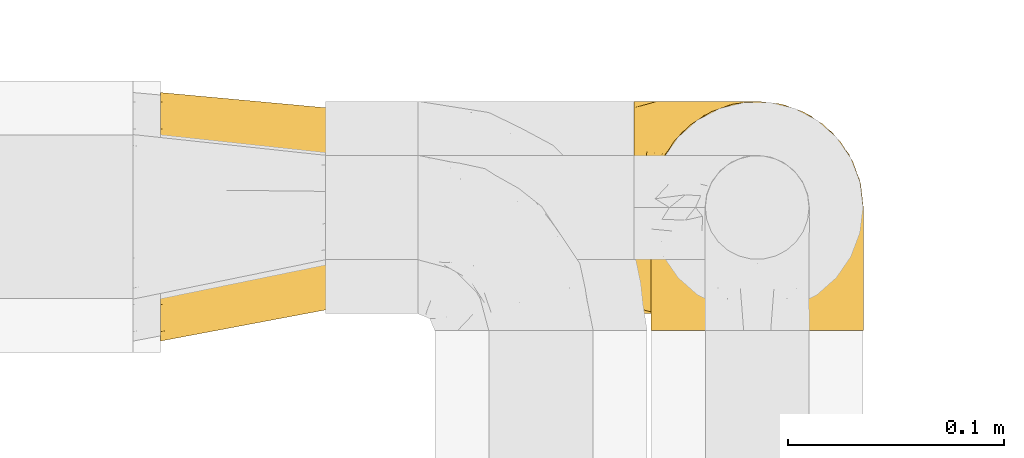
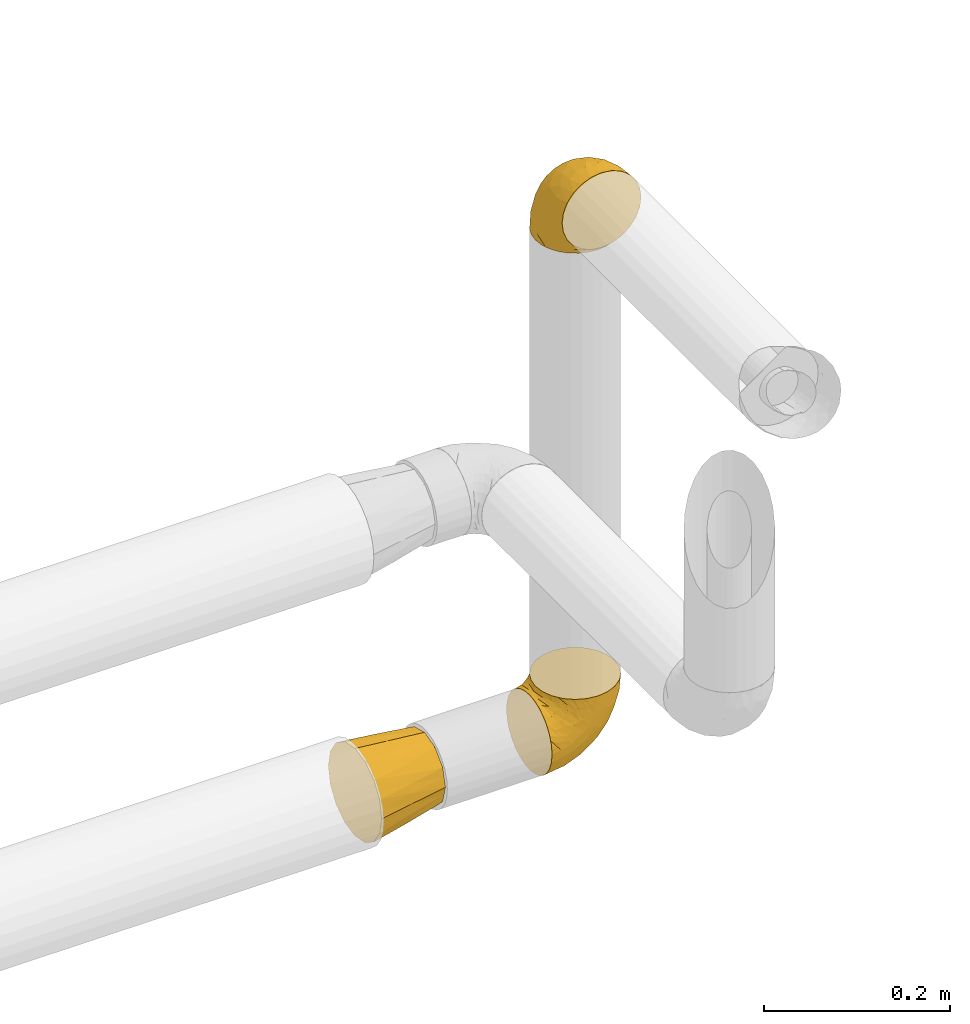
# One storey, part 417 of 827: 3 coverings.
"""IFC2X3 building model written with IfcOpenShell, lengths in millimetres."""

from ifc_helpers import new_model, entity, si_unit, converted_unit, derived_unit, direction, frame, origin, place, context, subcontext, project, spatial, faceted_brep, element, save


model = new_model("IFC2X3")

# Units and contexts
model_context = context("Model", 3, precision=0.01, world=origin(), true_north=direction((6.12303176911189e-17, 1.0)))
body_context = subcontext(model_context, "Body", "Model", "MODEL_VIEW")
ifc_project = project(units=[si_unit("LENGTHUNIT", "METRE", prefix="MILLI"), si_unit("AREAUNIT", "SQUARE_METRE"), si_unit("VOLUMEUNIT", "CUBIC_METRE"), converted_unit("PLANEANGLEUNIT", "DEGREE", entity("IfcRatioMeasure", 0.0174532925199433), si_unit("PLANEANGLEUNIT", "RADIAN"), dimensions=[0, 0, 0, 0, 0, 0, 0]), si_unit("MASSUNIT", "GRAM", prefix="KILO"), derived_unit("MASSDENSITYUNIT", [(si_unit("MASSUNIT", "GRAM", prefix="KILO"), 1), (si_unit("LENGTHUNIT", "METRE"), -3)]), derived_unit("MOMENTOFINERTIAUNIT", [(si_unit("LENGTHUNIT", "METRE"), 4)]), si_unit("TIMEUNIT", "SECOND"), si_unit("FREQUENCYUNIT", "HERTZ"), si_unit("THERMODYNAMICTEMPERATUREUNIT", "DEGREE_CELSIUS"), derived_unit("THERMALTRANSMITTANCEUNIT", [(si_unit("MASSUNIT", "GRAM", prefix="KILO"), 1), (si_unit("THERMODYNAMICTEMPERATUREUNIT", "KELVIN"), -1), (si_unit("TIMEUNIT", "SECOND"), -3)]), derived_unit("VOLUMETRICFLOWRATEUNIT", [(si_unit("LENGTHUNIT", "METRE"), 3), (si_unit("TIMEUNIT", "SECOND"), -1)]), derived_unit("MASSFLOWRATEUNIT", [(si_unit("MASSUNIT", "GRAM", prefix="KILO"), 1), (si_unit("TIMEUNIT", "SECOND"), -1)]), derived_unit("ROTATIONALFREQUENCYUNIT", [(si_unit("TIMEUNIT", "SECOND"), -1)]), si_unit("ELECTRICCURRENTUNIT", "AMPERE"), si_unit("ELECTRICVOLTAGEUNIT", "VOLT"), si_unit("POWERUNIT", "WATT"), si_unit("FORCEUNIT", "NEWTON", prefix="KILO"), si_unit("ILLUMINANCEUNIT", "LUX"), si_unit("LUMINOUSFLUXUNIT", "LUMEN"), si_unit("LUMINOUSINTENSITYUNIT", "CANDELA"), derived_unit("USERDEFINED", [(si_unit("MASSUNIT", "GRAM", prefix="KILO"), -1), (si_unit("LENGTHUNIT", "METRE"), -2), (si_unit("TIMEUNIT", "SECOND"), 3), (si_unit("LUMINOUSFLUXUNIT", "LUMEN"), 1)]), derived_unit("LINEARVELOCITYUNIT", [(si_unit("LENGTHUNIT", "METRE"), 1), (si_unit("TIMEUNIT", "SECOND"), -1)]), si_unit("PRESSUREUNIT", "PASCAL"), derived_unit("USERDEFINED", [(si_unit("LENGTHUNIT", "METRE"), -2), (si_unit("MASSUNIT", "GRAM", prefix="KILO"), 1), (si_unit("TIMEUNIT", "SECOND"), -2)]), derived_unit("LINEARFORCEUNIT", [(si_unit("MASSUNIT", "GRAM", prefix="KILO"), 1), (si_unit("LENGTHUNIT", "METRE"), 1), (si_unit("TIMEUNIT", "SECOND"), -2), (si_unit("LENGTHUNIT", "METRE"), -1)]), derived_unit("PLANARFORCEUNIT", [(si_unit("MASSUNIT", "GRAM", prefix="KILO"), 1), (si_unit("LENGTHUNIT", "METRE"), 1), (si_unit("TIMEUNIT", "SECOND"), -2), (si_unit("LENGTHUNIT", "METRE"), -2)])], contexts=[model_context])

# Site, building, storey
site_placement = place(None, origin())
site = spatial("IfcSite", under=ifc_project, at=site_placement, CompositionType="ELEMENT")
building_placement = place(site_placement, origin())
building = spatial("IfcBuilding", under=site, at=building_placement, CompositionType="ELEMENT")
storey_placement = place(building_placement, frame((0.0, 0.0, 28200.0)))
storey = spatial("IfcBuildingStorey", under=building, at=storey_placement, Name="08", CompositionType="ELEMENT", Elevation=28200.0)

# Coverings
covering_1_placement = place(storey_placement, frame((50321.29, 19086.93, 1941.4)))
element("IfcCovering", 1, at=covering_1_placement, inside=storey, Name=":ADSK_", ObjectType=":ADSK_", PredefinedType="INSULATION", context=body_context, shape_type="Brep", body=[
    faceted_brep([(1.6, 58.6, 1.6), (2.83, 69.54, 1.6), (6.47, 79.93, 1.6), (12.32, 89.25, 1.6), (20.11, 97.03, 1.6), (29.43, 102.88, 1.6), (39.81, 106.51, 1.6), (50.75, 107.75, 1.6), (61.69, 106.51, 1.6), (72.08, 102.87, 1.6), (81.4, 97.02, 1.6), (89.18, 89.23, 1.6), (95.03, 79.91, 1.6), (98.66, 69.53, 1.6), (99.9, 58.6, 1.6), (99.25, 52.89, 1.6), (98.66, 47.65, 1.6), (96.84, 42.46, 1.6), (95.02, 37.26, 1.6), (89.17, 27.94, 1.6), (81.38, 20.16, 1.6), (72.06, 14.31, 1.6), (61.68, 10.68, 1.6), (50.75, 9.45, 1.6), (39.8, 10.68, 1.6), (29.41, 14.32, 1.6), (20.09, 20.17, 1.6), (12.31, 27.96, 1.6), (6.46, 37.28, 1.6), (4.64, 42.47, 1.6), (2.83, 47.66, 1.6), (2.24, 52.89, 1.6), (1.92, 55.75, 1.6), (63.47, 1.6, 11.12), (75.32, 1.6, 16.03), (80.41, 1.6, 19.94), (85.5, 1.6, 23.84), (89.4, 1.6, 28.93), (93.31, 1.6, 34.02), (95.77, 1.6, 39.95), (98.22, 1.6, 45.87), (99.14, 1.6, 52.86), (99.52, 1.6, 55.73), (99.9, 1.6, 58.6), (98.22, 1.6, 71.32), (93.31, 1.6, 83.17), (85.5, 1.6, 93.35), (75.32, 1.6, 101.16), (63.47, 1.6, 106.07), (50.75, 1.6, 107.75), (38.02, 1.6, 106.07), (26.17, 1.6, 101.16), (15.99, 1.6, 93.35), (8.18, 1.6, 83.17), (3.27, 1.6, 71.32), (1.6, 1.6, 58.6), (2.35, 1.6, 52.86), (3.27, 1.6, 45.87), (5.73, 1.6, 39.95), (8.18, 1.6, 34.02), (12.09, 1.6, 28.93), (15.99, 1.6, 23.84), (21.08, 1.6, 19.94), (26.17, 1.6, 16.03), (38.02, 1.6, 11.12), (50.75, 1.6, 9.45), (42.18, 69.96, 81.82), (28.42, 59.59, 84.02), (37.78, 51.96, 93.05), (50.75, 34.4, 102.55), (42.85, 23.37, 104.83), (50.75, 13.68, 105.83), (24.75, 41.52, 91.87), (33.81, 26.26, 101.74), (22.57, 20.18, 97.07), (7.18, 72.33, 38.45), (2.73, 65.88, 22.17), (3.09, 57.55, 42.04), (6.92, 23.76, 77.69), (11.58, 46.5, 75.76), (5.17, 46.57, 62.11), (2.71, 21.17, 66.08), (1.6, 23.41, 54.26), (1.6, 17.92, 55.35), (1.6, 12.43, 56.44), (1.6, 9.72, 56.98), (1.6, 7.01, 57.52), (14.18, 26.77, 87.84), (5.88, 76.59, 19.41), (41.06, 95.55, 48.89), (36.25, 102.57, 26.34), (28.62, 92.89, 44.55), (1.6, 54.26, 23.41), (1.6, 51.17, 28.03), (1.6, 48.08, 32.65), (1.6, 44.99, 37.28), (1.6, 41.9, 41.9), (10.85, 85.16, 20.6), (38.35, 85.97, 63.36), (9.6, 59.58, 62.21), (26.24, 99.5, 19.94), (50.75, 105.83, 13.68), (19.31, 53.59, 80.85), (16.41, 67.0, 66.53), (24.56, 71.56, 71.06), (50.75, 87.47, 63.99), (50.75, 75.73, 75.73), (18.47, 92.24, 26.77), (1.6, 58.06, 4.31), (1.6, 57.52, 7.01), (1.6, 56.44, 12.43), (1.6, 55.35, 17.92), (14.36, 81.33, 43.43), (20.64, 80.35, 56.23), (2.32, 39.44, 54.97), (50.75, 102.55, 34.4), (1.6, 37.28, 44.99), (1.6, 32.65, 48.08), (1.6, 28.03, 51.17), (50.75, 63.99, 87.47), (33.88, 74.55, 74.55), (29.24, 83.62, 60.86), (50.75, 95.01, 49.19), (50.75, 49.19, 95.01), (2.8, 46.96, 10.27), (2.48, 8.77, 48.79), (2.7, 18.28, 45.16), (3.2, 11.68, 44.99), (32.98, 11.79, 6.17), (24.67, 15.69, 7.65), (2.95, 42.49, 21.59), (2.19, 47.41, 19.96), (17.92, 7.94, 21.0), (12.02, 9.27, 27.2), (25.73, 7.98, 14.83), (16.63, 13.4, 19.7), (25.6, 13.04, 10.93), (36.72, 7.36, 9.63), (10.66, 23.46, 19.97), (6.87, 30.46, 21.13), (11.12, 26.54, 14.14), (10.31, 6.76, 30.2), (12.84, 26.46, 8.12), (17.38, 20.77, 9.93), (9.74, 20.68, 24.62), (4.63, 40.26, 11.87), (50.75, 7.15, 7.15), (42.52, 9.28, 5.32), (3.12, 38.78, 26.68), (17.58, 18.27, 13.92), (3.97, 31.78, 30.67), (5.94, 12.75, 36.65), (2.73, 22.96, 42.89), (6.23, 17.55, 34.04), (3.45, 27.63, 36.6), (10.84, 15.23, 26.41), (7.98, 33.25, 10.07), (7.33, 32.43, 15.83), (2.39, 27.9, 41.99), (75.76, 7.97, 14.83), (90.65, 15.22, 26.4), (83.57, 7.93, 21.01), (84.85, 13.38, 19.71), (71.05, 13.12, 5.72), (98.54, 42.49, 21.6), (99.3, 47.4, 19.96), (99.9, 51.17, 28.03), (96.86, 40.24, 11.87), (84.1, 20.76, 9.93), (99.9, 12.43, 56.44), (99.9, 7.01, 57.52), (99.9, 4.31, 58.06), (88.63, 26.44, 8.13), (90.36, 26.52, 14.15), (98.29, 11.68, 44.99), (95.55, 12.75, 36.65), (89.47, 9.27, 27.21), (95.26, 17.55, 34.04), (91.18, 6.76, 30.2), (93.49, 33.21, 10.06), (94.15, 32.41, 15.83), (99.01, 8.77, 48.79), (98.76, 22.96, 42.89), (98.85, 18.48, 45.38), (99.9, 56.44, 12.43), (98.69, 46.95, 10.28), (64.78, 7.36, 9.64), (99.9, 17.92, 55.35), (99.9, 23.41, 54.26), (62.91, 9.85, 6.05), (99.9, 57.52, 7.01), (99.9, 56.98, 9.72), (99.9, 48.08, 32.65), (98.37, 38.78, 26.68), (83.9, 18.25, 13.92), (99.9, 44.99, 37.28), (97.51, 31.74, 30.66), (94.62, 30.45, 21.14), (98.04, 27.63, 36.59), (91.73, 20.65, 24.6), (99.9, 55.35, 17.92), (99.9, 54.26, 23.41), (75.87, 13.03, 10.93), (90.83, 23.44, 19.97), (99.1, 27.9, 41.99), (99.9, 32.65, 48.08), (99.9, 28.03, 51.17), (99.9, 37.28, 44.99), (99.9, 41.9, 41.9), (99.09, 39.74, 55.26), (58.64, 23.37, 104.83), (87.31, 26.77, 87.84), (89.93, 46.18, 75.91), (82.22, 53.54, 80.84), (76.74, 41.53, 91.87), (73.12, 59.61, 83.98), (95.54, 76.79, 19.16), (98.7, 66.11, 22.37), (98.79, 21.17, 66.08), (63.71, 51.96, 93.05), (67.68, 26.26, 101.74), (78.92, 20.18, 97.07), (94.57, 23.76, 77.69), (72.88, 92.88, 44.55), (65.25, 102.57, 26.34), (60.44, 95.54, 48.9), (76.94, 71.63, 70.99), (67.61, 74.55, 74.55), (94.38, 72.51, 37.8), (59.31, 69.96, 81.82), (83.03, 92.23, 26.77), (90.66, 85.15, 20.6), (80.8, 80.45, 56.15), (72.22, 83.65, 60.85), (98.39, 57.57, 42.06), (92.31, 63.68, 57.03), (63.11, 85.95, 63.4), (75.27, 99.49, 19.94), (87.15, 81.23, 43.59), (96.03, 47.07, 62.61), (85.1, 66.99, 66.52)], [[[0, 1, 2, 3, 4, 5, 6, 7, 8, 9, 10, 11, 12, 13, 14, 15, 16, 17, 18, 19, 20, 21, 22, 23, 24, 25, 26, 27, 28, 29, 30, 31, 32]], [[33, 34, 35, 36, 37, 38, 39, 40, 41, 42, 43, 44, 45, 46, 47, 48, 49, 50, 51, 52, 53, 54, 55, 56, 57, 58, 59, 60, 61, 62, 63, 64, 65]], [[66, 67, 68]], [[69, 70, 71]], [[68, 72, 73]], [[73, 72, 74]], [[75, 76, 77]], [[78, 79, 80]], [[51, 50, 73]], [[81, 82, 83, 84, 85, 86, 55]], [[52, 87, 53]], [[74, 52, 51]], [[2, 1, 88]], [[89, 90, 91]], [[77, 92, 93, 94, 95, 96]], [[55, 54, 81]], [[78, 53, 87]], [[5, 90, 6]], [[88, 76, 75]], [[97, 3, 2]], [[89, 91, 98]], [[99, 80, 79]], [[90, 5, 100]], [[74, 87, 52]], [[100, 5, 4]], [[90, 101, 6]], [[79, 102, 103]], [[102, 67, 104]], [[105, 98, 106]], [[107, 4, 3]], [[76, 0, 108, 109, 110, 111, 92]], [[107, 112, 113]], [[114, 77, 96]], [[89, 115, 90]], [[114, 96, 116, 117, 118, 82]], [[75, 97, 88]], [[119, 66, 68]], [[50, 71, 70]], [[100, 91, 90]], [[99, 77, 80]], [[102, 104, 103]], [[97, 107, 3]], [[80, 81, 78]], [[107, 97, 112]], [[68, 73, 70]], [[66, 98, 120]], [[78, 81, 54]], [[114, 81, 80]], [[53, 78, 54]], [[78, 87, 79]], [[102, 87, 72]], [[79, 103, 99]], [[4, 107, 100]], [[91, 100, 107]], [[88, 97, 2]], [[112, 97, 75]], [[99, 112, 75]], [[103, 104, 113]], [[91, 121, 98]], [[89, 105, 122, 115]], [[101, 90, 115]], [[101, 7, 6]], [[88, 1, 76]], [[0, 76, 1]], [[92, 77, 76]], [[73, 74, 51]], [[87, 74, 72]], [[81, 114, 82]], [[77, 114, 80]], [[87, 102, 79]], [[67, 102, 72]], [[68, 67, 72]], [[67, 120, 104]], [[120, 121, 104]], [[104, 121, 113]], [[121, 120, 98]], [[91, 107, 113]], [[91, 113, 121]], [[103, 113, 112]], [[106, 98, 66]], [[105, 89, 98]], [[106, 66, 119]], [[67, 66, 120]], [[68, 69, 123, 119]], [[50, 49, 71]], [[50, 70, 73]], [[112, 99, 103]], [[77, 99, 75]], [[69, 68, 70]], [[29, 124, 110]], [[84, 83, 125]], [[126, 82, 118]], [[59, 58, 127]], [[25, 128, 129]], [[130, 93, 131]], [[132, 62, 133]], [[134, 135, 136]], [[137, 65, 64]], [[64, 134, 137]], [[138, 139, 140]], [[111, 110, 124, 92]], [[134, 136, 137]], [[134, 64, 63]], [[141, 61, 60]], [[125, 58, 57]], [[142, 143, 140]], [[142, 26, 143]], [[127, 83, 82]], [[28, 124, 29]], [[108, 0, 32, 31, 30, 110, 109]], [[30, 29, 110]], [[135, 144, 138]], [[28, 145, 124]], [[57, 56, 55, 86, 85, 84]], [[146, 147, 23]], [[24, 23, 147]], [[25, 143, 26]], [[95, 94, 148]], [[24, 128, 25]], [[149, 138, 143]], [[124, 145, 131]], [[127, 58, 125]], [[150, 148, 139]], [[127, 126, 151]], [[151, 59, 127]], [[152, 151, 126]], [[153, 154, 155]], [[153, 133, 141]], [[145, 28, 27]], [[142, 156, 27]], [[157, 148, 130]], [[61, 133, 62]], [[134, 132, 135]], [[147, 128, 24]], [[65, 137, 146]], [[146, 137, 147]], [[128, 137, 136]], [[137, 128, 147]], [[128, 136, 129]], [[149, 129, 136]], [[25, 129, 143]], [[158, 152, 117]], [[152, 118, 117]], [[153, 151, 152]], [[158, 116, 154]], [[144, 150, 138]], [[153, 152, 158]], [[133, 153, 155]], [[133, 155, 132]], [[60, 151, 141]], [[135, 132, 155]], [[134, 63, 132]], [[144, 135, 155]], [[135, 138, 149]], [[155, 154, 144]], [[150, 154, 96]], [[154, 150, 144]], [[148, 94, 130]], [[82, 126, 127]], [[118, 152, 126]], [[150, 96, 95]], [[139, 148, 157]], [[150, 95, 148]], [[93, 92, 131]], [[130, 145, 156]], [[130, 94, 93]], [[84, 125, 57]], [[127, 125, 83]], [[140, 139, 157]], [[150, 139, 138]], [[140, 157, 142]], [[138, 140, 143]], [[156, 142, 157]], [[27, 26, 142]], [[130, 156, 157]], [[145, 27, 156]], [[132, 63, 62]], [[124, 131, 92]], [[130, 131, 145]], [[129, 149, 143]], [[135, 149, 136]], [[141, 133, 61]], [[60, 59, 151]], [[141, 151, 153]], [[116, 96, 154]], [[153, 158, 154]], [[158, 117, 116]], [[34, 33, 159]], [[160, 161, 162]], [[22, 21, 163]], [[164, 165, 166]], [[19, 18, 167]], [[168, 21, 20]], [[42, 41, 40, 169, 170, 171, 43]], [[172, 173, 168]], [[174, 38, 175]], [[176, 177, 178]], [[179, 164, 180]], [[40, 181, 169]], [[182, 183, 175]], [[17, 184, 185]], [[65, 146, 186]], [[187, 174, 188]], [[23, 22, 189]], [[174, 39, 38]], [[15, 14, 190, 191, 184, 16]], [[181, 40, 39]], [[192, 193, 164]], [[194, 163, 168]], [[33, 186, 159]], [[180, 173, 172]], [[195, 196, 193]], [[18, 185, 167]], [[173, 180, 197]], [[198, 199, 196]], [[200, 201, 185, 184]], [[184, 17, 16]], [[18, 17, 185]], [[202, 159, 186]], [[194, 168, 203]], [[189, 163, 202]], [[204, 205, 182]], [[187, 181, 174]], [[160, 177, 176]], [[206, 183, 182]], [[206, 182, 205]], [[201, 165, 185]], [[165, 164, 167]], [[172, 179, 180]], [[202, 194, 162]], [[176, 161, 160]], [[65, 186, 33]], [[163, 189, 22]], [[175, 177, 182]], [[174, 183, 188]], [[177, 198, 204]], [[199, 160, 162]], [[198, 207, 204]], [[175, 38, 37]], [[198, 177, 160]], [[178, 177, 175]], [[176, 35, 161]], [[34, 159, 161]], [[162, 161, 159]], [[202, 162, 159]], [[199, 162, 203]], [[196, 199, 203]], [[198, 160, 199]], [[193, 197, 180]], [[208, 198, 196]], [[188, 183, 206]], [[175, 183, 174]], [[193, 192, 195]], [[195, 208, 196]], [[197, 196, 203]], [[180, 164, 193]], [[168, 163, 21]], [[166, 165, 201]], [[166, 192, 164]], [[189, 202, 186]], [[186, 146, 189]], [[23, 189, 146]], [[174, 181, 39]], [[169, 181, 187]], [[196, 197, 193]], [[173, 203, 168]], [[203, 173, 197]], [[172, 168, 20]], [[20, 19, 172]], [[179, 172, 19]], [[19, 167, 179]], [[164, 179, 167]], [[35, 176, 36]], [[35, 34, 161]], [[185, 165, 167]], [[162, 194, 203]], [[163, 194, 202]], [[176, 178, 36]], [[37, 36, 178]], [[175, 37, 178]], [[177, 204, 182]], [[207, 198, 208]], [[207, 205, 204]], [[209, 188, 206, 205, 207, 208]], [[48, 210, 71]], [[211, 212, 213]], [[214, 213, 215]], [[216, 217, 13]], [[218, 43, 171, 170, 169, 187, 188]], [[219, 220, 214]], [[47, 46, 221]], [[210, 48, 220]], [[211, 222, 212]], [[222, 45, 44]], [[221, 220, 47]], [[47, 220, 48]], [[221, 211, 214]], [[223, 224, 225]], [[211, 46, 45]], [[226, 227, 215]], [[43, 218, 44]], [[217, 216, 228]], [[219, 215, 229]], [[14, 13, 217]], [[224, 9, 8]], [[10, 230, 11]], [[11, 231, 12]], [[232, 223, 233]], [[234, 208, 195, 192, 166, 201]], [[235, 234, 228]], [[222, 44, 218]], [[106, 229, 236]], [[224, 237, 9]], [[231, 238, 228]], [[9, 237, 10]], [[115, 224, 101]], [[239, 234, 235]], [[231, 11, 230]], [[223, 230, 237]], [[224, 8, 101]], [[223, 236, 233]], [[225, 115, 122, 105]], [[216, 12, 231]], [[209, 234, 239]], [[210, 219, 69]], [[219, 214, 215]], [[229, 119, 219]], [[209, 218, 188]], [[239, 212, 222]], [[239, 222, 218]], [[45, 222, 211]], [[235, 212, 239]], [[213, 212, 240]], [[223, 237, 224]], [[230, 10, 237]], [[238, 231, 230]], [[216, 231, 228]], [[232, 230, 223]], [[235, 238, 240]], [[115, 225, 224]], [[233, 236, 227]], [[8, 7, 101]], [[234, 209, 208]], [[218, 209, 239]], [[217, 228, 234]], [[13, 12, 216]], [[234, 201, 217]], [[217, 201, 200, 184, 191, 190, 14]], [[211, 221, 46]], [[220, 221, 214]], [[71, 210, 69]], [[71, 49, 48]], [[219, 210, 220]], [[226, 215, 213]], [[211, 213, 214]], [[226, 213, 240]], [[215, 227, 229]], [[232, 240, 238]], [[233, 227, 226]], [[232, 233, 226]], [[236, 223, 225]], [[240, 232, 226]], [[232, 238, 230]], [[225, 105, 236]], [[236, 105, 106]], [[236, 229, 227]], [[123, 69, 219, 119]], [[106, 119, 229]], [[238, 235, 228]], [[212, 235, 240]]]),
])
covering_2_placement = place(storey_placement, frame((50313.44, 19094.78, 1249.25)))
element("IfcCovering", 2, at=covering_2_placement, inside=storey, Name=":ADSK_", ObjectType=":ADSK_", PredefinedType="INSULATION", context=body_context, shape_type="Brep", body=[
    faceted_brep([(1.6, 99.9, 50.75), (1.6, 98.66, 39.8), (1.6, 95.02, 29.41), (1.6, 89.17, 20.09), (1.6, 81.38, 12.31), (1.6, 72.06, 6.46), (1.6, 61.68, 2.83), (1.6, 50.75, 1.6), (1.6, 39.8, 2.83), (1.6, 29.41, 6.47), (1.6, 20.09, 12.32), (1.6, 12.31, 20.11), (1.6, 6.46, 29.43), (1.6, 2.83, 39.81), (1.6, 1.6, 50.75), (1.6, 2.24, 56.45), (1.6, 2.83, 61.69), (1.6, 4.65, 66.88), (1.6, 6.47, 72.08), (1.6, 12.32, 81.4), (1.6, 20.11, 89.18), (1.6, 29.43, 95.03), (1.6, 39.81, 98.66), (1.6, 50.75, 99.9), (1.6, 61.69, 98.66), (1.6, 72.08, 95.02), (1.6, 81.4, 89.17), (1.6, 89.18, 81.38), (1.6, 95.03, 72.06), (1.6, 96.85, 66.87), (1.6, 98.66, 61.68), (1.6, 99.25, 56.45), (1.6, 99.57, 53.6), (11.12, 38.02, 107.75), (16.03, 26.17, 107.75), (19.94, 21.08, 107.75), (23.84, 15.99, 107.75), (28.93, 12.09, 107.75), (34.02, 8.18, 107.75), (39.95, 5.73, 107.75), (45.87, 3.27, 107.75), (52.86, 2.35, 107.75), (55.73, 1.97, 107.75), (58.6, 1.6, 107.75), (71.32, 3.27, 107.75), (83.17, 8.18, 107.75), (93.35, 15.99, 107.75), (101.16, 26.17, 107.75), (106.07, 38.02, 107.75), (107.75, 50.75, 107.75), (106.07, 63.47, 107.75), (101.16, 75.32, 107.75), (93.35, 85.5, 107.75), (83.17, 93.31, 107.75), (71.32, 98.22, 107.75), (58.6, 99.9, 107.75), (52.86, 99.14, 107.75), (45.87, 98.22, 107.75), (39.95, 95.77, 107.75), (34.02, 93.31, 107.75), (28.93, 89.4, 107.75), (23.84, 85.5, 107.75), (19.94, 80.41, 107.75), (16.03, 75.32, 107.75), (11.12, 63.47, 107.75), (9.45, 50.75, 107.75), (81.82, 59.31, 39.38), (84.02, 73.08, 49.75), (93.05, 63.72, 57.38), (102.55, 50.75, 74.94), (104.83, 58.64, 85.97), (105.83, 50.75, 95.66), (91.87, 76.74, 67.82), (101.74, 67.68, 83.09), (97.07, 78.92, 89.16), (38.45, 94.31, 37.01), (22.17, 98.76, 43.46), (42.04, 98.4, 51.79), (77.69, 94.57, 85.58), (75.76, 89.91, 62.84), (62.11, 96.32, 62.77), (66.08, 98.79, 88.17), (54.26, 99.9, 85.93), (55.35, 99.9, 91.42), (56.44, 99.9, 96.91), (56.98, 99.9, 99.62), (57.52, 99.9, 102.33), (87.84, 87.31, 82.57), (19.41, 95.61, 32.75), (48.89, 60.43, 13.79), (26.34, 65.24, 6.77), (44.55, 72.87, 16.46), (23.41, 99.9, 55.08), (28.03, 99.9, 58.17), (32.65, 99.9, 61.26), (37.28, 99.9, 64.35), (41.9, 99.9, 67.44), (20.6, 90.65, 24.18), (63.36, 63.14, 23.37), (62.21, 91.89, 49.76), (19.94, 75.25, 9.84), (13.68, 50.75, 3.51), (80.85, 82.18, 55.75), (66.53, 85.08, 42.34), (71.06, 76.93, 37.78), (63.99, 50.75, 21.87), (75.73, 50.75, 33.61), (26.77, 83.02, 17.1), (4.31, 99.9, 51.28), (7.01, 99.9, 51.82), (12.43, 99.9, 52.9), (17.92, 99.9, 53.99), (43.43, 87.13, 28.01), (56.23, 80.85, 28.99), (54.97, 99.17, 69.9), (34.4, 50.75, 6.79), (44.99, 99.9, 72.06), (48.08, 99.9, 76.69), (51.17, 99.9, 81.31), (87.47, 50.75, 45.35), (74.55, 67.61, 34.79), (60.86, 72.25, 25.72), (49.19, 50.75, 14.33), (95.01, 50.75, 60.15), (10.27, 98.69, 62.38), (48.79, 99.01, 100.57), (45.16, 98.79, 91.06), (44.99, 98.29, 97.66), (6.17, 68.51, 97.55), (7.65, 76.82, 93.65), (21.59, 98.54, 66.85), (19.96, 99.3, 61.93), (21.0, 83.57, 101.4), (27.2, 89.47, 100.07), (14.83, 75.76, 101.36), (19.7, 84.86, 95.94), (10.93, 75.89, 96.3), (9.63, 64.77, 101.98), (19.97, 90.83, 85.88), (21.13, 94.62, 78.88), (14.14, 90.37, 82.8), (30.2, 91.18, 102.58), (36.65, 95.55, 96.59), (8.12, 88.65, 82.88), (9.93, 84.11, 88.57), (24.62, 91.75, 88.67), (11.87, 96.86, 69.08), (7.15, 50.75, 102.19), (5.32, 58.97, 100.06), (26.68, 98.37, 70.56), (13.92, 83.91, 91.07), (30.67, 97.52, 77.56), (42.89, 98.76, 86.38), (34.04, 95.26, 91.79), (36.6, 98.04, 81.71), (26.41, 90.65, 94.11), (10.07, 93.51, 76.09), (15.83, 94.16, 76.91), (41.99, 99.1, 81.44), (14.83, 25.73, 101.37), (26.4, 10.84, 94.12), (21.01, 17.92, 101.41), (19.71, 16.64, 95.96), (5.72, 30.44, 96.22), (21.6, 2.95, 66.85), (19.96, 2.19, 61.94), (28.03, 1.6, 58.17), (11.87, 4.63, 69.1), (9.93, 17.39, 88.58), (56.44, 1.6, 96.91), (57.52, 1.6, 102.33), (58.06, 1.6, 105.04), (8.13, 12.86, 82.9), (14.15, 11.13, 82.82), (44.99, 3.2, 97.66), (36.65, 5.94, 96.59), (30.2, 10.31, 102.58), (10.06, 8.0, 76.13), (15.83, 7.34, 76.93), (48.79, 2.48, 100.57), (42.89, 2.73, 86.38), (45.38, 2.64, 90.86), (12.43, 1.6, 52.9), (10.28, 2.8, 62.39), (9.64, 36.71, 101.98), (55.35, 1.6, 91.42), (54.26, 1.6, 85.93), (6.05, 38.59, 99.49), (7.01, 1.6, 51.82), (9.72, 1.6, 52.36), (32.65, 1.6, 61.26), (26.68, 3.12, 70.56), (13.92, 17.59, 91.09), (37.28, 1.6, 64.35), (30.66, 3.98, 77.6), (21.14, 6.87, 78.89), (36.59, 3.45, 81.71), (24.6, 9.76, 88.69), (17.92, 1.6, 53.99), (23.41, 1.6, 55.08), (10.93, 25.62, 96.31), (19.97, 10.67, 85.9), (41.99, 2.39, 81.45), (48.08, 1.6, 76.69), (34.04, 6.23, 91.79), (27.21, 12.02, 100.07), (51.17, 1.6, 81.31), (44.99, 1.6, 72.06), (41.9, 1.6, 67.44), (55.26, 2.4, 69.6), (104.83, 42.85, 85.97), (87.84, 14.18, 82.57), (75.91, 11.56, 63.16), (80.84, 19.27, 55.81), (91.87, 24.75, 67.81), (83.98, 28.37, 49.73), (19.16, 5.95, 32.55), (22.37, 2.79, 43.23), (66.08, 2.71, 88.17), (93.05, 37.78, 57.38), (101.74, 33.81, 83.08), (97.07, 22.57, 89.16), (77.69, 6.92, 85.58), (44.55, 28.61, 16.46), (26.34, 36.24, 6.77), (48.9, 41.05, 13.8), (70.99, 24.55, 37.71), (74.55, 33.88, 34.8), (37.8, 7.11, 36.83), (63.4, 38.38, 23.39), (81.82, 42.18, 39.38), (26.77, 18.46, 17.12), (20.6, 10.84, 24.19), (56.15, 20.69, 28.89), (60.85, 29.27, 25.69), (42.06, 3.1, 51.77), (57.03, 9.18, 45.66), (19.94, 26.23, 9.85), (43.59, 14.34, 28.11), (62.61, 5.46, 62.27), (66.52, 16.39, 42.35)], [[[0, 1, 2, 3, 4, 5, 6, 7, 8, 9, 10, 11, 12, 13, 14, 15, 16, 17, 18, 19, 20, 21, 22, 23, 24, 25, 26, 27, 28, 29, 30, 31, 32]], [[33, 34, 35, 36, 37, 38, 39, 40, 41, 42, 43, 44, 45, 46, 47, 48, 49, 50, 51, 52, 53, 54, 55, 56, 57, 58, 59, 60, 61, 62, 63, 64, 65]], [[66, 67, 68]], [[69, 70, 71]], [[68, 72, 73]], [[73, 72, 74]], [[75, 76, 77]], [[78, 79, 80]], [[51, 50, 73]], [[81, 82, 83, 84, 85, 86, 55]], [[52, 87, 53]], [[74, 52, 51]], [[2, 1, 88]], [[89, 90, 91]], [[77, 92, 93, 94, 95, 96]], [[55, 54, 81]], [[78, 53, 87]], [[5, 90, 6]], [[88, 76, 75]], [[97, 3, 2]], [[89, 91, 98]], [[99, 80, 79]], [[90, 5, 100]], [[74, 87, 52]], [[100, 5, 4]], [[90, 101, 6]], [[79, 102, 103]], [[102, 67, 104]], [[105, 98, 106]], [[107, 4, 3]], [[76, 0, 108, 109, 110, 111, 92]], [[107, 112, 113]], [[114, 77, 96]], [[89, 115, 90]], [[114, 96, 116, 117, 118, 82]], [[75, 97, 88]], [[119, 66, 68]], [[50, 71, 70]], [[100, 91, 90]], [[99, 77, 80]], [[102, 104, 103]], [[97, 107, 3]], [[80, 81, 78]], [[107, 97, 112]], [[68, 73, 70]], [[66, 98, 120]], [[78, 81, 54]], [[114, 81, 80]], [[53, 78, 54]], [[78, 87, 79]], [[102, 87, 72]], [[79, 103, 99]], [[4, 107, 100]], [[91, 100, 107]], [[88, 97, 2]], [[112, 97, 75]], [[99, 112, 75]], [[103, 104, 113]], [[91, 121, 98]], [[89, 105, 122, 115]], [[101, 90, 115]], [[101, 7, 6]], [[88, 1, 76]], [[0, 76, 1]], [[92, 77, 76]], [[73, 74, 51]], [[87, 74, 72]], [[81, 114, 82]], [[77, 114, 80]], [[87, 102, 79]], [[67, 102, 72]], [[68, 67, 72]], [[67, 120, 104]], [[120, 121, 104]], [[104, 121, 113]], [[121, 120, 98]], [[91, 107, 113]], [[91, 113, 121]], [[103, 113, 112]], [[106, 98, 66]], [[105, 89, 98]], [[106, 66, 119]], [[67, 66, 120]], [[68, 69, 123, 119]], [[50, 49, 71]], [[50, 70, 73]], [[112, 99, 103]], [[77, 99, 75]], [[69, 68, 70]], [[29, 124, 110]], [[84, 83, 125]], [[126, 82, 118]], [[59, 58, 127]], [[25, 128, 129]], [[130, 93, 131]], [[132, 62, 133]], [[134, 135, 136]], [[137, 65, 64]], [[64, 134, 137]], [[138, 139, 140]], [[111, 110, 124, 92]], [[134, 136, 137]], [[134, 64, 63]], [[141, 60, 142]], [[125, 58, 57]], [[143, 144, 140]], [[143, 26, 144]], [[127, 83, 82]], [[28, 124, 29]], [[108, 0, 32, 31, 30, 110, 109]], [[30, 29, 110]], [[135, 145, 138]], [[28, 146, 124]], [[57, 56, 55, 86, 85, 84]], [[147, 148, 23]], [[24, 23, 148]], [[25, 144, 26]], [[95, 94, 149]], [[24, 128, 25]], [[150, 138, 144]], [[124, 146, 131]], [[127, 58, 125]], [[151, 149, 139]], [[127, 126, 142]], [[142, 59, 127]], [[152, 142, 126]], [[153, 154, 155]], [[153, 133, 141]], [[146, 28, 27]], [[143, 156, 27]], [[157, 149, 130]], [[61, 133, 62]], [[134, 132, 135]], [[148, 128, 24]], [[65, 137, 147]], [[147, 137, 148]], [[128, 137, 136]], [[137, 128, 148]], [[128, 136, 129]], [[150, 129, 136]], [[25, 129, 144]], [[158, 152, 117]], [[152, 118, 117]], [[153, 142, 152]], [[158, 116, 154]], [[145, 151, 138]], [[153, 152, 158]], [[133, 153, 155]], [[133, 155, 132]], [[153, 141, 142]], [[135, 132, 155]], [[134, 63, 132]], [[145, 135, 155]], [[135, 138, 150]], [[155, 154, 145]], [[151, 154, 96]], [[154, 151, 145]], [[149, 94, 130]], [[82, 126, 127]], [[118, 152, 126]], [[151, 96, 95]], [[139, 149, 157]], [[151, 95, 149]], [[93, 92, 131]], [[130, 146, 156]], [[130, 94, 93]], [[84, 125, 57]], [[127, 125, 83]], [[140, 139, 157]], [[151, 139, 138]], [[140, 157, 143]], [[138, 140, 144]], [[156, 143, 157]], [[27, 26, 143]], [[130, 156, 157]], [[146, 27, 156]], [[132, 63, 62]], [[124, 131, 92]], [[130, 131, 146]], [[129, 150, 144]], [[135, 150, 136]], [[60, 141, 61]], [[60, 59, 142]], [[133, 61, 141]], [[116, 96, 154]], [[153, 158, 154]], [[158, 117, 116]], [[34, 33, 159]], [[160, 161, 162]], [[22, 21, 163]], [[164, 165, 166]], [[19, 18, 167]], [[168, 21, 20]], [[42, 41, 40, 169, 170, 171, 43]], [[172, 173, 168]], [[174, 38, 175]], [[176, 37, 36]], [[177, 164, 178]], [[40, 179, 169]], [[180, 181, 175]], [[17, 182, 183]], [[65, 147, 184]], [[185, 174, 186]], [[23, 22, 187]], [[174, 39, 38]], [[15, 14, 188, 189, 182, 16]], [[179, 40, 39]], [[190, 191, 164]], [[192, 163, 168]], [[33, 184, 159]], [[178, 173, 172]], [[193, 194, 191]], [[18, 183, 167]], [[173, 178, 195]], [[196, 197, 194]], [[198, 199, 183, 182]], [[182, 17, 16]], [[18, 17, 183]], [[200, 159, 184]], [[192, 168, 201]], [[187, 163, 200]], [[202, 203, 180]], [[185, 179, 174]], [[160, 204, 205]], [[206, 181, 180]], [[206, 180, 203]], [[199, 165, 183]], [[165, 164, 167]], [[172, 177, 178]], [[200, 192, 162]], [[205, 161, 160]], [[65, 184, 33]], [[163, 187, 22]], [[175, 204, 180]], [[174, 181, 186]], [[204, 196, 202]], [[197, 160, 162]], [[196, 207, 202]], [[205, 204, 176]], [[196, 204, 160]], [[176, 204, 175]], [[205, 35, 161]], [[34, 159, 161]], [[162, 161, 159]], [[200, 162, 159]], [[197, 162, 201]], [[194, 197, 201]], [[196, 160, 197]], [[191, 195, 178]], [[208, 196, 194]], [[186, 181, 206]], [[175, 181, 174]], [[191, 190, 193]], [[193, 208, 194]], [[195, 194, 201]], [[178, 164, 191]], [[168, 163, 21]], [[166, 165, 199]], [[166, 190, 164]], [[187, 200, 184]], [[184, 147, 187]], [[23, 187, 147]], [[174, 179, 39]], [[169, 179, 185]], [[194, 195, 191]], [[173, 201, 168]], [[201, 173, 195]], [[172, 168, 20]], [[20, 19, 172]], [[177, 172, 19]], [[19, 167, 177]], [[164, 177, 167]], [[35, 205, 36]], [[35, 34, 161]], [[183, 165, 167]], [[162, 192, 201]], [[163, 192, 200]], [[175, 38, 37]], [[205, 176, 36]], [[175, 37, 176]], [[204, 202, 180]], [[207, 196, 208]], [[207, 203, 202]], [[209, 186, 206, 203, 207, 208]], [[48, 210, 71]], [[211, 212, 213]], [[214, 213, 215]], [[216, 217, 13]], [[218, 43, 171, 170, 169, 185, 186]], [[219, 220, 214]], [[47, 46, 221]], [[210, 48, 220]], [[211, 222, 212]], [[222, 45, 44]], [[221, 220, 47]], [[47, 220, 48]], [[221, 211, 214]], [[223, 224, 225]], [[211, 46, 45]], [[226, 227, 215]], [[43, 218, 44]], [[217, 216, 228]], [[227, 229, 230]], [[14, 13, 217]], [[224, 9, 8]], [[10, 231, 11]], [[11, 232, 12]], [[233, 223, 234]], [[235, 208, 193, 190, 166, 199]], [[236, 235, 228]], [[222, 44, 218]], [[106, 230, 229]], [[224, 237, 9]], [[232, 238, 228]], [[9, 237, 10]], [[115, 224, 101]], [[239, 235, 236]], [[232, 11, 231]], [[223, 231, 237]], [[224, 8, 101]], [[223, 229, 234]], [[225, 115, 122, 105]], [[216, 12, 232]], [[209, 235, 239]], [[210, 219, 69]], [[219, 214, 215]], [[230, 119, 219]], [[209, 218, 186]], [[239, 212, 222]], [[239, 222, 218]], [[45, 222, 211]], [[236, 212, 239]], [[213, 212, 240]], [[223, 237, 224]], [[231, 10, 237]], [[238, 232, 231]], [[216, 232, 228]], [[233, 231, 223]], [[236, 238, 240]], [[115, 225, 224]], [[234, 229, 227]], [[8, 7, 101]], [[235, 209, 208]], [[218, 209, 239]], [[217, 228, 235]], [[13, 12, 216]], [[235, 199, 217]], [[217, 199, 198, 182, 189, 188, 14]], [[211, 221, 46]], [[220, 221, 214]], [[71, 210, 69]], [[71, 49, 48]], [[219, 210, 220]], [[226, 215, 213]], [[211, 213, 214]], [[226, 213, 240]], [[215, 227, 230]], [[233, 240, 238]], [[234, 227, 226]], [[233, 234, 226]], [[229, 223, 225]], [[240, 233, 226]], [[233, 238, 231]], [[225, 105, 229]], [[229, 105, 106]], [[106, 119, 230]], [[123, 69, 219, 119]], [[215, 230, 219]], [[238, 236, 228]], [[212, 236, 240]]]),
])
covering_3_placement = place(storey_placement, frame((50096.03, 19082.13, 1240.9)))
element("IfcCovering", 3, at=covering_3_placement, inside=storey, Name=":ADSK_", ObjectType=":ADSK_", PredefinedType="INSULATION", context=body_context, shape_type="Brep", body=[
    faceted_brep([(89.0, 40.9, 98.07), (89.0, 32.67, 89.83), (89.0, 24.43, 81.6), (89.0, 21.42, 70.35), (89.0, 18.4, 59.1), (89.0, 21.42, 47.85), (89.0, 24.43, 36.6), (89.0, 32.67, 28.36), (89.0, 40.9, 20.12), (89.0, 52.15, 17.11), (89.0, 63.4, 14.1), (89.0, 74.65, 17.11), (89.0, 85.9, 20.12), (89.0, 94.14, 28.36), (89.0, 102.37, 36.6), (89.0, 105.39, 47.85), (89.0, 108.4, 59.1), (89.0, 105.39, 70.35), (89.0, 102.37, 81.6), (89.0, 94.14, 89.83), (89.0, 85.9, 98.07), (89.0, 74.65, 101.08), (89.0, 63.4, 104.1), (89.0, 52.15, 101.08), (0.0, 99.75, 99.75), (0.0, 105.99, 90.43), (0.0, 112.22, 81.1), (0.0, 114.55, 69.4), (0.0, 116.6, 59.1), (0.0, 114.41, 48.09), (0.0, 112.22, 37.09), (0.0, 105.99, 27.76), (0.0, 99.75, 18.44), (0.0, 90.43, 12.2), (0.0, 81.1, 5.97), (0.0, 69.4, 3.64), (0.0, 59.1, 1.6), (0.0, 48.09, 3.78), (0.0, 37.09, 5.97), (0.0, 27.76, 12.2), (0.0, 18.44, 18.44), (0.0, 12.2, 27.76), (0.0, 5.97, 37.09), (0.0, 3.63, 48.84), (0.0, 1.6, 59.1), (0.0, 3.78, 70.1), (0.0, 5.97, 81.1), (0.0, 12.2, 90.43), (0.0, 18.44, 99.75), (0.0, 27.76, 105.99), (0.0, 37.09, 112.22), (0.0, 48.84, 114.56), (0.0, 59.1, 116.6), (0.0, 70.1, 114.41), (0.0, 81.1, 112.22), (0.0, 90.43, 105.99), (41.99, 9.53, 59.1), (41.45, 11.55, 44.42), (41.53, 15.68, 34.48), (44.5, 22.29, 25.8), (43.62, 48.41, 9.34), (45.16, 39.04, 13.02), (44.5, 30.05, 18.44), (41.99, 61.13, 7.49), (42.19, 61.14, 7.52), (41.48, 75.79, 9.55), (41.49, 85.74, 13.67), (44.5, 94.55, 20.14), (43.62, 110.96, 46.3), (45.16, 107.35, 36.86), (44.5, 101.91, 27.9), (42.19, 112.71, 59.1), (41.48, 110.64, 73.79), (41.49, 106.52, 83.73), (44.5, 100.21, 92.39), (43.62, 74.0, 108.85), (45.16, 83.52, 105.17), (44.5, 92.45, 99.75), (42.19, 61.14, 110.67), (41.99, 61.13, 110.7), (41.45, 46.43, 108.65), (41.53, 36.49, 104.52), (44.5, 27.95, 98.05), (43.62, 11.45, 71.89), (45.16, 15.21, 81.33), (44.5, 20.59, 90.29)], [[[0, 1, 2, 3, 4, 5, 6, 7, 8, 9, 10, 11, 12, 13, 14, 15, 16, 17, 18, 19, 20, 21, 22, 23]], [[24, 25, 26, 27, 28, 29, 30, 31, 32, 33, 34, 35, 36, 37, 38, 39, 40, 41, 42, 43, 44, 45, 46, 47, 48, 49, 50, 51, 52, 53, 54, 55]], [[56, 43, 57]], [[43, 56, 44]], [[57, 42, 58]], [[57, 58, 5]], [[6, 5, 58]], [[58, 59, 6]], [[60, 9, 61]], [[58, 42, 41]], [[8, 7, 62]], [[62, 61, 8]], [[4, 56, 5]], [[40, 62, 59]], [[56, 57, 5]], [[7, 59, 62]], [[61, 39, 38]], [[57, 43, 42]], [[59, 41, 40]], [[39, 61, 62]], [[6, 59, 7]], [[41, 59, 58]], [[62, 40, 39]], [[10, 9, 60]], [[38, 37, 60]], [[9, 8, 61]], [[60, 63, 64, 10]], [[37, 36, 63]], [[38, 60, 61]], [[63, 60, 37]], [[64, 35, 65]], [[35, 64, 63, 36]], [[65, 34, 66]], [[65, 66, 11]], [[12, 11, 66]], [[66, 67, 12]], [[68, 15, 69]], [[66, 34, 33]], [[14, 13, 70]], [[70, 69, 14]], [[10, 64, 11]], [[32, 70, 67]], [[64, 65, 11]], [[13, 67, 70]], [[69, 31, 30]], [[65, 35, 34]], [[67, 33, 32]], [[31, 69, 70]], [[12, 67, 13]], [[33, 67, 66]], [[70, 32, 31]], [[16, 15, 68]], [[30, 29, 68]], [[15, 14, 69]], [[16, 68, 71]], [[29, 28, 71]], [[30, 68, 69]], [[71, 68, 29]], [[71, 27, 72]], [[27, 71, 28]], [[72, 26, 73]], [[72, 73, 17]], [[18, 17, 73]], [[73, 74, 18]], [[75, 21, 76]], [[73, 26, 25]], [[20, 19, 77]], [[77, 76, 20]], [[16, 71, 17]], [[24, 77, 74]], [[71, 72, 17]], [[19, 74, 77]], [[76, 55, 54]], [[72, 27, 26]], [[74, 25, 24]], [[55, 76, 77]], [[18, 74, 19]], [[25, 74, 73]], [[77, 24, 55]], [[22, 21, 75]], [[54, 53, 75]], [[21, 20, 76]], [[22, 75, 78]], [[53, 52, 79, 78]], [[54, 75, 76]], [[78, 75, 53]], [[79, 51, 80]], [[51, 79, 52]], [[80, 50, 81]], [[80, 81, 23]], [[0, 23, 81]], [[81, 82, 0]], [[83, 3, 84]], [[81, 50, 49]], [[2, 1, 85]], [[85, 84, 2]], [[23, 22, 78, 79]], [[48, 85, 82]], [[79, 80, 23]], [[1, 82, 85]], [[84, 47, 46]], [[80, 51, 50]], [[82, 49, 48]], [[47, 84, 85]], [[0, 82, 1]], [[49, 82, 81]], [[85, 48, 47]], [[4, 3, 83]], [[46, 45, 83]], [[3, 2, 84]], [[4, 83, 56]], [[45, 44, 56]], [[46, 83, 84]], [[56, 83, 45]]]),
])

save(model, "model.ifc")
